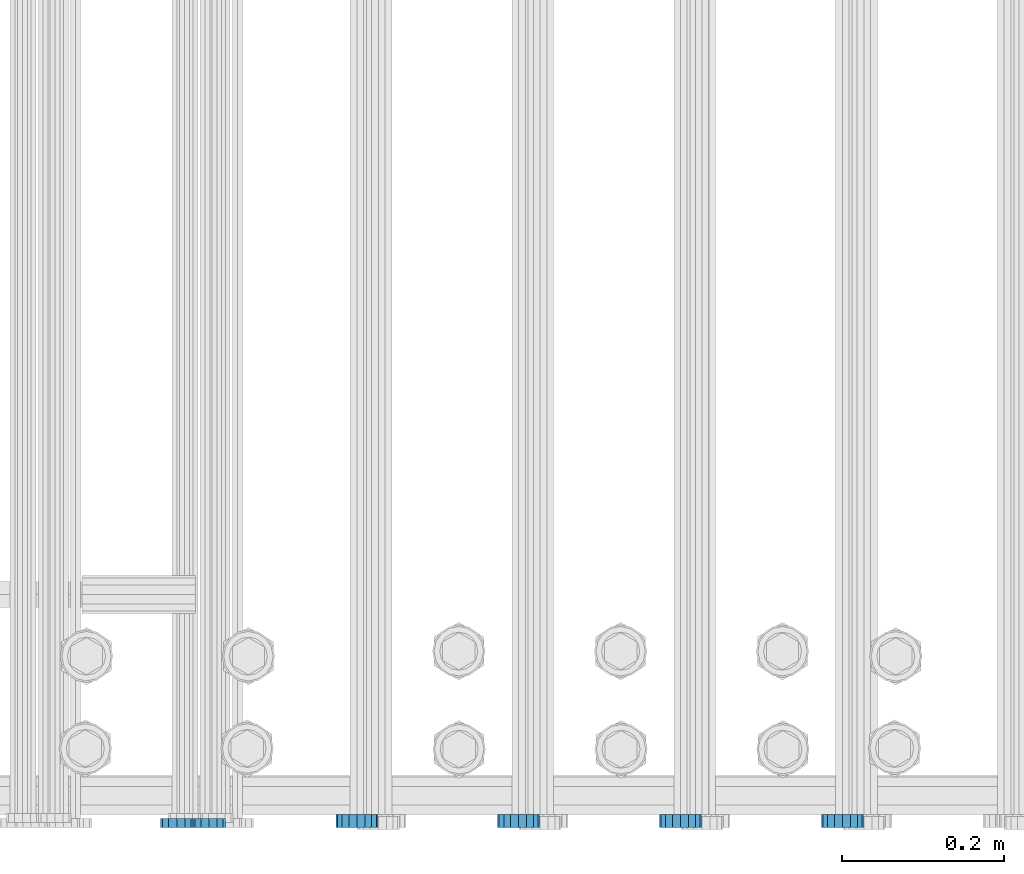
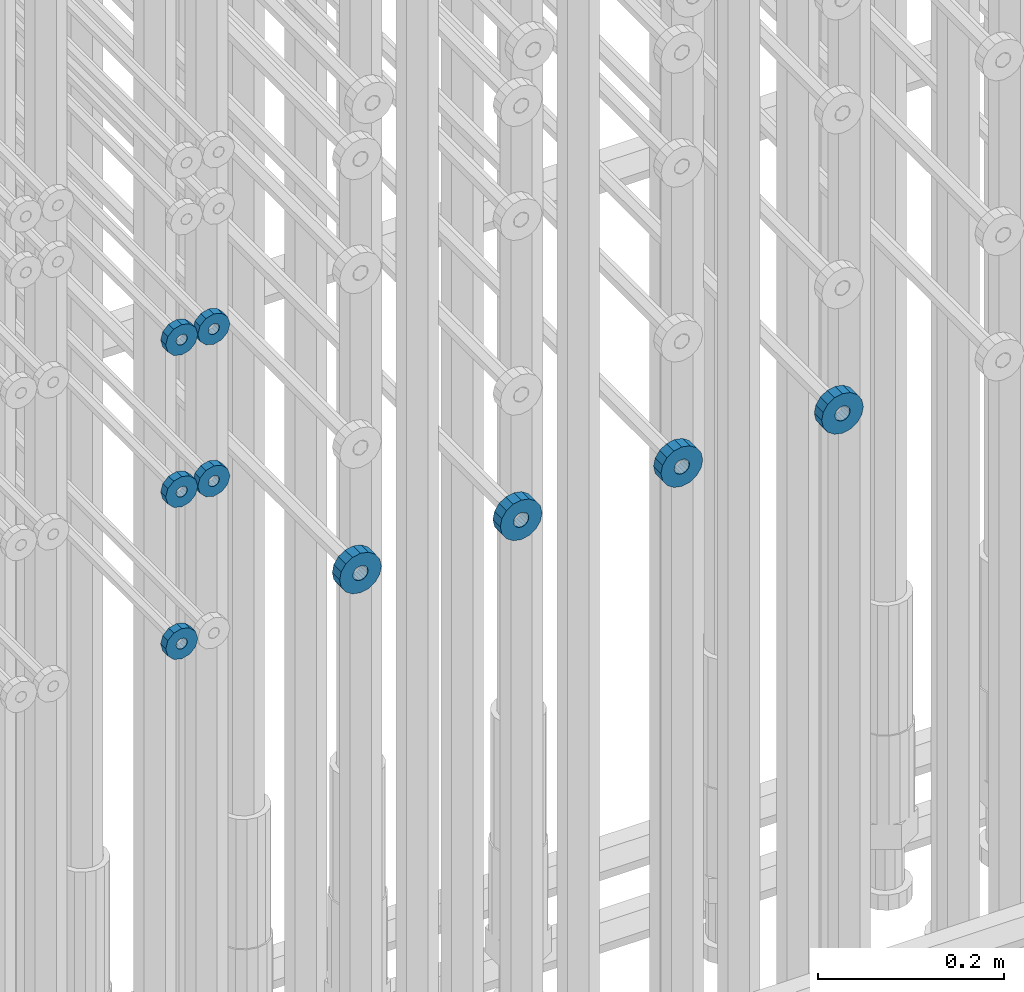
# One storey, part 134 of 177: 9 beams.
"""IFC2X3 building model written with IfcOpenShell, lengths in millimetres."""

import ifcopenshell
import ifcopenshell.guid

model = None  # the IFC model being written
_history = None  # IfcOwnerHistory: only IFC2X3 demands one
_inside = {}  # id of a spatial element -> (the spatial element, [elements in it])
_under = {}  # id of a project, library or spatial element -> (it, [spatial elements below it])
_declared = {}  # id of a project -> (the project, [libraries it declares])
_typed = {}  # id of a type object -> (the type object, [elements of that type])
_made_of = {}  # id of a material, layer set ... -> (it, [elements and type objects made of it])


def new_model(schema):
    """Start an empty IFC model of exactly this schema.

    Asked for "IFC4X3", IfcOpenShell would pick the latest addendum, in which some entities
    have other attributes; the version numbers below select the first issue.
    IFC2X3 requires an IfcOwnerHistory on every rooted entity: one is made here for all.
    """
    global model, _history
    if schema == "IFC4X3":
        model = ifcopenshell.file(schema_version=(4, 3, 0, 0))
    else:
        model = ifcopenshell.file(schema=schema)
    _inside.clear()
    _under.clear()
    _declared.clear()
    _typed.clear()
    _made_of.clear()
    _history = None
    if model.schema == "IFC2X3":
        org = make("IfcOrganization", Name="unknown")
        user = make(
            "IfcPersonAndOrganization",
            ThePerson=make("IfcPerson", FamilyName="unknown"),
            TheOrganization=org,
        )
        app = make(
            "IfcApplication",
            ApplicationDeveloper=org,
            Version="unknown",
            ApplicationFullName="unknown",
            ApplicationIdentifier="unknown",
        )
        _history = make(
            "IfcOwnerHistory",
            OwningUser=user,
            OwningApplication=app,
            ChangeAction="ADDED",
            CreationDate=0,
        )
    return model


def make(cls, **values):
    """One entity of the class cls with the attributes given. An attribute that is None is left unset."""
    return model.create_entity(
        cls, **{name: value for name, value in values.items() if value is not None}
    )


def rooted(cls, **values):
    """An entity with a GlobalId (a new one), such as an element, a storey or a relation."""
    return make(cls, GlobalId=ifcopenshell.guid.new(), OwnerHistory=_history, **values)


def si_unit(unit_type, name, prefix=None):
    """IfcSIUnit, for example si_unit("LENGTHUNIT", "METRE", prefix="MILLI")."""
    return make("IfcSIUnit", UnitType=unit_type, Prefix=prefix, Name=name)


def assignment(units):
    """IfcUnitAssignment: the units of a project."""
    return None if units is None else make("IfcUnitAssignment", Units=units)


def point(xyz):
    """IfcCartesianPoint."""
    return None if xyz is None else make("IfcCartesianPoint", Coordinates=xyz)


def direction(xyz):
    """IfcDirection."""
    return None if xyz is None else make("IfcDirection", DirectionRatios=xyz)


def frame(location, z_axis=None, x_axis=None):
    """IfcAxis2Placement3D, a coordinate frame: its origin and axes. An axis left out is left unset."""
    return make(
        "IfcAxis2Placement3D",
        Location=point(location),
        Axis=direction(z_axis),
        RefDirection=direction(x_axis),
    )


def origin_with_axes():
    """The frame at (0, 0, 0) with the z axis (0, 0, 1) and the x axis (1, 0, 0) written out."""
    return frame((0.0, 0.0, 0.0), z_axis=(0.0, 0.0, 1.0), x_axis=(1.0, 0.0, 0.0))


def place(relative_to, where):
    """IfcLocalPlacement: puts the frame where relative to a parent placement (None: the world)."""
    return make(
        "IfcLocalPlacement", PlacementRelTo=relative_to, RelativePlacement=where
    )


def context(
    kind, dimensions, precision=None, world=None, true_north=None, identifier=None
):
    """IfcGeometricRepresentationContext, for example the 3D "Model" context."""
    return make(
        "IfcGeometricRepresentationContext",
        ContextIdentifier=identifier,
        ContextType=kind,
        CoordinateSpaceDimension=dimensions,
        Precision=precision,
        WorldCoordinateSystem=world,
        TrueNorth=true_north,
    )


def subcontext(parent, identifier, kind, view, scale=None):
    """IfcGeometricRepresentationSubContext, for example "Body" below "Model"."""
    return make(
        "IfcGeometricRepresentationSubContext",
        ContextIdentifier=identifier,
        ContextType=kind,
        ParentContext=parent,
        TargetScale=scale,
        TargetView=view,
    )


def project(units=None, contexts=None):
    """IfcProject with its units and contexts."""
    return rooted(
        "IfcProject",
        Name="project",
        RepresentationContexts=contexts,
        UnitsInContext=assignment(units),
    )


def spatial(cls, under=None, at=None, **own):
    """A site, building, storey or space (cls), placed at a placement, below another one or the project."""
    s = rooted(cls, ObjectPlacement=at, **own)
    if under is not None:
        _under.setdefault(under.id(), (under, []))[1].append(s)
    return s


def faces_of(points, faces, orient=None, outer=None):
    """IfcFace entities. A face is a list of loops; a loop is a list of indices into points, from 0.

    orient and outer hold one flag for each loop. By default every Orientation is true, the
    first loop of a face is its IfcFaceOuterBound and the others are IfcFaceBound.
    """
    made = []
    for i, loops in enumerate(faces):
        bounds = []
        for j, loop in enumerate(loops):
            is_outer = j == 0 if outer is None else outer[i][j]
            bounds.append(
                make(
                    "IfcFaceOuterBound" if is_outer else "IfcFaceBound",
                    Bound=make("IfcPolyLoop", Polygon=[points[k] for k in loop]),
                    Orientation=True if orient is None else orient[i][j],
                )
            )
        made.append(make("IfcFace", Bounds=bounds))
    return made


def faceted_brep(points, faces, orient=None, outer=None, voids=None):
    """IfcFacetedBrep: a solid bounded by flat faces; with voids (closed shells), ...WithVoids."""
    shared = [point(p) for p in points]
    hull = make("IfcClosedShell", CfsFaces=faces_of(shared, faces, orient, outer))
    if voids is None:
        return make("IfcFacetedBrep", Outer=hull)
    return make(
        "IfcFacetedBrepWithVoids",
        Outer=hull,
        Voids=[
            make(cls, CfsFaces=faces_of(shared, fs, o, b)) for cls, fs, o, b in voids
        ],
    )


def shape(context_of_items, identifier, shape_type, items):
    """IfcShapeRepresentation: the items that make up one representation, for example the "Body"."""
    return make(
        "IfcShapeRepresentation",
        ContextOfItems=context_of_items,
        RepresentationIdentifier=identifier,
        RepresentationType=shape_type,
        Items=items,
    )


def material(Name=None, Category=None):
    """IfcMaterial."""
    return make("IfcMaterial", Name=Name, Category=Category)


def made_of(thing, what):
    """Note that an element or type object is made of a material, layer set ...; save() writes the relation."""
    if what is not None:
        _made_of.setdefault(what.id(), (what, []))[1].append(thing)
    return thing


def type_object(cls, material=None, **own):
    """A type object (cls), such as IfcWallType, which elements share."""
    return made_of(rooted(cls, **own), material)


def element(
    cls,
    number,
    at=None,
    inside=None,
    cuts=None,
    type_object=None,
    material=None,
    context=None,
    identifier="Body",
    shape_type=None,
    held_by="IfcProductDefinitionShape",
    body=None,
    shapes=None,
    **own,
):
    """One element of the class cls, such as IfcWall. Its Tag is "e" and its number.

    at: its placement. inside: the storey or other place that contains it. cuts: it is an
    opening in that element (IfcRelVoidsElement). A single representation is given by context,
    identifier, shape_type and body (its items); several are given by shapes. held_by: the class
    of the entity that holds the representations. save() writes the other relations.
    """
    e = rooted(cls, Tag="e%d" % number, ObjectPlacement=at, **own)
    if body is not None:
        shapes = [shape(context, identifier, shape_type, body)]
    if shapes is not None:
        e.Representation = make(held_by, Representations=shapes)
    if inside is not None:
        _inside.setdefault(inside.id(), (inside, []))[1].append(e)
    if cuts is not None:
        rooted(
            "IfcRelVoidsElement", RelatingBuildingElement=cuts, RelatedOpeningElement=e
        )
    if type_object is not None:
        _typed.setdefault(type_object.id(), (type_object, []))[1].append(e)
    return made_of(e, material)


def aggregate(whole, parts):
    """IfcRelAggregates: a whole, such as a stair, and the parts it consists of."""
    return rooted("IfcRelAggregates", RelatingObject=whole, RelatedObjects=parts)


def save(model, path):
    """Write the relations noted so far, then the file.

    IfcRelAggregates (storeys below a building ...), IfcRelContainedInSpatialStructure (elements
    in a storey), IfcRelDefinesByType, IfcRelAssociatesMaterial and IfcRelDeclares: one each for
    every whole, place, type object, material and project.
    """
    for whole, parts in _under.values():
        aggregate(whole, parts)
    for where, things in _inside.values():
        rooted(
            "IfcRelContainedInSpatialStructure",
            RelatedElements=things,
            RelatingStructure=where,
        )
    for kind, things in _typed.values():
        rooted("IfcRelDefinesByType", RelatedObjects=things, RelatingType=kind)
    for what, things in _made_of.values():
        rooted("IfcRelAssociatesMaterial", RelatedObjects=things, RelatingMaterial=what)
    for by, libraries in _declared.values():
        rooted("IfcRelDeclares", RelatingContext=by, RelatedDefinitions=libraries)
    model.write(path)


model = new_model("IFC2X3")

# Units and contexts
model_context_1 = context("Model", 3, precision=1e-05, world=origin_with_axes())
model_context_2 = context("Model", 3, precision=1e-05, world=origin_with_axes())
body_context = subcontext(model_context_2, "Body", "Model", "MODEL_VIEW")
ifc_project = project(units=[si_unit("LENGTHUNIT", "METRE", prefix="MILLI"), si_unit("AREAUNIT", "SQUARE_METRE"), si_unit("VOLUMEUNIT", "CUBIC_METRE"), si_unit("MASSUNIT", "GRAM", prefix="KILO"), si_unit("TIMEUNIT", "SECOND"), si_unit("PLANEANGLEUNIT", "RADIAN"), si_unit("SOLIDANGLEUNIT", "STERADIAN"), si_unit("THERMODYNAMICTEMPERATUREUNIT", "DEGREE_CELSIUS"), si_unit("LUMINOUSINTENSITYUNIT", "LUMEN")], contexts=[model_context_1])

# Site, building, storey
site_placement = place(None, origin_with_axes())
site = spatial("IfcSite", under=ifc_project, at=site_placement, CompositionType="ELEMENT")
building_placement = place(site_placement, origin_with_axes())
building = spatial("IfcBuilding", under=site, at=building_placement, Name="Undefined", CompositionType="ELEMENT")
storey_placement = place(building_placement, origin_with_axes())
storey = spatial("IfcBuildingStorey", under=building, at=storey_placement, Name="Undefined", CompositionType="ELEMENT", Elevation=0.0)

# Beams
ifc_material = material(Name="STEEL/Steel_Undefined")
beam_type_1 = type_object("IfcBeamType", PredefinedType="NOTDEFINED")
beam_1_placement = place(storey_placement, frame((2031926.99847313, 6205070.98588034, 20639.9868114202), z_axis=(0.0, 0.0, -1.0), x_axis=(0.0, -1.0, 0.0)))
element("IfcBeam", 1, at=beam_1_placement, inside=storey, type_object=beam_type_1, material=ifc_material, context=body_context, shape_type="Brep", body=[
    faceted_brep([(-3.63797880709171e-12, -7.0, -2.3283064365387e-10), (-8.62348444298797e-13, -6.06217782649107, 3.5), (10.9999999999964, -6.06217782665044, 3.49999999976717), (10.9999999999964, -7.0, -2.3283064365387e-10), (-3.63797880709171e-12, -3.5, 6.06217782618478), (11.0, -3.5, 6.06217782618478), (-1.72469688859759e-12, 0.0, 7.0), (11.0, 0.0, 6.99999999976717), (-3.63797880709171e-12, 3.5, 6.06217782618478), (11.0, 3.5, 6.06217782618478), (-8.62348444298795e-13, 6.06217782649107, 3.5), (10.9999999999964, 6.06217782665044, 3.49999999976717), (-3.63797880709171e-12, 7.0, -2.3283064365387e-10), (10.9999999999964, 7.0, -2.3283064365387e-10), (8.62348444298797e-13, 6.06217782649107, -3.5), (10.9999999999964, 6.06217782665044, -3.50000000023283), (-3.63797880709171e-12, 3.5, -6.06217782665044), (10.9999999999964, 3.5, -6.06217782665044), (1.72469688859759e-12, -2.72004641033163e-15, -7.0), (10.9999999999964, 0.0, -7.00000000023283), (-3.63797880709171e-12, -3.5, -6.06217782665044), (10.9999999999964, -3.5, -6.06217782665044), (8.62348444298796e-13, -6.06217782649107, -3.5), (10.9999999999964, -6.06217782665044, -3.50000000023283), (0.0, -20.0000000009313, 0.0), (0.0, -17.320508075878, -10.0), (10.9999999999964, -17.320508075878, -10.0000000002328), (10.9999999999964, -20.0, -2.3283064365387e-10), (0.0, -10.0000000009313, -17.3205080756452), (11.0, -10.0, -17.320508075878), (0.0, -1.86264514923096e-09, -19.9999999998836), (10.9999999999964, 0.0, -20.0000000002328), (0.0, 9.99999999906868, -17.3205080755288), (11.0, 10.0, -17.320508075878), (0.0, 17.320508075878, -10.0), (10.9999999999964, 17.320508075878, -10.0000000002328), (0.0, 19.9999999990687, 0.0), (10.9999999999964, 20.0, -2.3283064365387e-10), (0.0, 17.3205080740154, 10.0), (11.0, 17.320508075878, 9.99999999976717), (0.0, 9.99999999906868, 17.3205080757616), (10.9999999999964, 10.0, 17.3205080754124), (0.0, 0.0, 20.0000000001164), (10.9999999999964, 0.0, 19.9999999997672), (0.0, -10.0000000009313, 17.3205080757616), (10.9999999999964, -10.0, 17.3205080754124), (0.0, -17.3205080777407, 10.0000000001164), (11.0, -17.320508075878, 9.99999999976717)], [[[0, 1, 2, 3]], [[1, 4, 5, 2]], [[4, 6, 7, 5]], [[6, 8, 9, 7]], [[8, 10, 11, 9]], [[10, 12, 13, 11]], [[12, 14, 15, 13]], [[14, 16, 17, 15]], [[16, 18, 19, 17]], [[18, 20, 21, 19]], [[20, 22, 23, 21]], [[22, 0, 3, 23]], [[24, 25, 26, 27]], [[25, 28, 29, 26]], [[28, 30, 31, 29]], [[30, 32, 33, 31]], [[32, 34, 35, 33]], [[34, 36, 37, 35]], [[36, 38, 39, 37]], [[38, 40, 41, 39]], [[40, 42, 43, 41]], [[42, 44, 45, 43]], [[44, 46, 47, 45]], [[46, 24, 27, 47]], [[29, 31, 33, 35, 37, 39, 41, 43, 45, 47, 27, 26], [5, 7, 9, 11, 13, 15, 17, 19, 21, 23, 3, 2]], [[46, 44, 42, 40, 38, 36, 34, 32, 30, 28, 25, 24], [22, 20, 18, 16, 14, 12, 10, 8, 6, 4, 1, 0]]]),
])
beam_2_placement = place(storey_placement, frame((2031886.99847313, 6205070.98588034, 20639.9868114202), z_axis=(0.0, 0.0, -1.0), x_axis=(0.0, -1.0, 0.0)))
element("IfcBeam", 2, at=beam_2_placement, inside=storey, type_object=beam_type_1, material=ifc_material, context=body_context, shape_type="Brep", body=[
    faceted_brep([(-3.63797880709171e-12, -7.0, -2.3283064365387e-10), (-8.62348444298797e-13, -6.06217782649107, 3.5), (10.9999999999964, -6.06217782665044, 3.49999999976717), (10.9999999999964, -7.0, -2.3283064365387e-10), (-3.63797880709171e-12, -3.5, 6.06217782618478), (11.0, -3.5, 6.06217782618478), (-1.72469688859759e-12, 0.0, 7.0), (11.0, 0.0, 6.99999999976717), (-3.63797880709171e-12, 3.5, 6.06217782618478), (11.0, 3.5, 6.06217782618478), (-8.62348444298795e-13, 6.06217782649107, 3.5), (10.9999999999964, 6.06217782665044, 3.49999999976717), (-3.63797880709171e-12, 7.0, -2.3283064365387e-10), (10.9999999999964, 7.0, -2.3283064365387e-10), (8.62348444298797e-13, 6.06217782649107, -3.5), (10.9999999999964, 6.06217782665044, -3.50000000023283), (-3.63797880709171e-12, 3.5, -6.06217782665044), (10.9999999999964, 3.5, -6.06217782665044), (1.72469688859759e-12, -2.72004641033163e-15, -7.0), (10.9999999999964, 0.0, -7.00000000023283), (-3.63797880709171e-12, -3.5, -6.06217782665044), (10.9999999999964, -3.5, -6.06217782665044), (8.62348444298796e-13, -6.06217782649107, -3.5), (10.9999999999964, -6.06217782665044, -3.50000000023283), (0.0, -20.0000000009313, 0.0), (0.0, -17.320508075878, -10.0), (10.9999999999964, -17.320508075878, -10.0000000002328), (10.9999999999964, -20.0, -2.3283064365387e-10), (0.0, -10.0000000009313, -17.3205080756452), (11.0, -10.0, -17.320508075878), (0.0, -1.86264514923096e-09, -19.9999999998836), (10.9999999999964, 0.0, -20.0000000002328), (0.0, 9.99999999906868, -17.3205080755288), (11.0, 10.0, -17.320508075878), (0.0, 17.320508075878, -10.0), (10.9999999999964, 17.320508075878, -10.0000000002328), (0.0, 19.9999999990687, 0.0), (10.9999999999964, 20.0, -2.3283064365387e-10), (0.0, 17.3205080740154, 10.0), (11.0, 17.320508075878, 9.99999999976717), (0.0, 9.99999999906868, 17.3205080757616), (10.9999999999964, 10.0, 17.3205080754124), (0.0, 0.0, 20.0000000001164), (10.9999999999964, 0.0, 19.9999999997672), (0.0, -10.0000000009313, 17.3205080757616), (10.9999999999964, -10.0, 17.3205080754124), (0.0, -17.3205080777407, 10.0000000001164), (11.0, -17.320508075878, 9.99999999976717)], [[[0, 1, 2, 3]], [[1, 4, 5, 2]], [[4, 6, 7, 5]], [[6, 8, 9, 7]], [[8, 10, 11, 9]], [[10, 12, 13, 11]], [[12, 14, 15, 13]], [[14, 16, 17, 15]], [[16, 18, 19, 17]], [[18, 20, 21, 19]], [[20, 22, 23, 21]], [[22, 0, 3, 23]], [[24, 25, 26, 27]], [[25, 28, 29, 26]], [[28, 30, 31, 29]], [[30, 32, 33, 31]], [[32, 34, 35, 33]], [[34, 36, 37, 35]], [[36, 38, 39, 37]], [[38, 40, 41, 39]], [[40, 42, 43, 41]], [[42, 44, 45, 43]], [[44, 46, 47, 45]], [[46, 24, 27, 47]], [[29, 31, 33, 35, 37, 39, 41, 43, 45, 47, 27, 26], [5, 7, 9, 11, 13, 15, 17, 19, 21, 23, 3, 2]], [[46, 44, 42, 40, 38, 36, 34, 32, 30, 28, 25, 24], [22, 20, 18, 16, 14, 12, 10, 8, 6, 4, 1, 0]]]),
])
beam_3_placement = place(storey_placement, frame((2031926.99847313, 6205070.98588034, 20439.9868114202), z_axis=(0.0, 0.0, -1.0), x_axis=(0.0, -1.0, 0.0)))
element("IfcBeam", 3, at=beam_3_placement, inside=storey, type_object=beam_type_1, material=ifc_material, context=body_context, shape_type="Brep", body=[
    faceted_brep([(-3.63797880709171e-12, -7.0, -2.3283064365387e-10), (-8.62348444298797e-13, -6.06217782649107, 3.5), (10.9999999999964, -6.06217782665044, 3.49999999976717), (10.9999999999964, -7.0, -2.3283064365387e-10), (-3.63797880709171e-12, -3.5, 6.06217782618478), (11.0, -3.5, 6.06217782618478), (-1.72469688859759e-12, 0.0, 7.0), (11.0, 0.0, 6.99999999976717), (-3.63797880709171e-12, 3.5, 6.06217782618478), (11.0, 3.5, 6.06217782618478), (-8.62348444298795e-13, 6.06217782649107, 3.5), (10.9999999999964, 6.06217782665044, 3.49999999976717), (-3.63797880709171e-12, 7.0, -2.3283064365387e-10), (10.9999999999964, 7.0, -2.3283064365387e-10), (8.62348444298797e-13, 6.06217782649107, -3.5), (10.9999999999964, 6.06217782665044, -3.50000000023283), (-3.63797880709171e-12, 3.5, -6.06217782665044), (10.9999999999964, 3.5, -6.06217782665044), (1.72469688859759e-12, -2.72004641033163e-15, -7.0), (10.9999999999964, 0.0, -7.00000000023283), (-3.63797880709171e-12, -3.5, -6.06217782665044), (10.9999999999964, -3.5, -6.06217782665044), (8.62348444298796e-13, -6.06217782649107, -3.5), (10.9999999999964, -6.06217782665044, -3.50000000023283), (0.0, -20.0000000009313, 0.0), (0.0, -17.320508075878, -10.0), (10.9999999999964, -17.320508075878, -10.0000000002328), (10.9999999999964, -20.0, -2.3283064365387e-10), (0.0, -10.0000000009313, -17.3205080756452), (11.0, -10.0, -17.320508075878), (0.0, -1.86264514923096e-09, -19.9999999998836), (10.9999999999964, 0.0, -20.0000000002328), (0.0, 9.99999999906868, -17.3205080755288), (11.0, 10.0, -17.320508075878), (0.0, 17.320508075878, -10.0), (10.9999999999964, 17.320508075878, -10.0000000002328), (0.0, 19.9999999990687, 0.0), (10.9999999999964, 20.0, -2.3283064365387e-10), (0.0, 17.3205080740154, 10.0), (11.0, 17.320508075878, 9.99999999976717), (0.0, 9.99999999906868, 17.3205080757616), (10.9999999999964, 10.0, 17.3205080754124), (0.0, 0.0, 20.0000000001164), (10.9999999999964, 0.0, 19.9999999997672), (0.0, -10.0000000009313, 17.3205080757616), (10.9999999999964, -10.0, 17.3205080754124), (0.0, -17.3205080777407, 10.0000000001164), (11.0, -17.320508075878, 9.99999999976717)], [[[0, 1, 2, 3]], [[1, 4, 5, 2]], [[4, 6, 7, 5]], [[6, 8, 9, 7]], [[8, 10, 11, 9]], [[10, 12, 13, 11]], [[12, 14, 15, 13]], [[14, 16, 17, 15]], [[16, 18, 19, 17]], [[18, 20, 21, 19]], [[20, 22, 23, 21]], [[22, 0, 3, 23]], [[24, 25, 26, 27]], [[25, 28, 29, 26]], [[28, 30, 31, 29]], [[30, 32, 33, 31]], [[32, 34, 35, 33]], [[34, 36, 37, 35]], [[36, 38, 39, 37]], [[38, 40, 41, 39]], [[40, 42, 43, 41]], [[42, 44, 45, 43]], [[44, 46, 47, 45]], [[46, 24, 27, 47]], [[29, 31, 33, 35, 37, 39, 41, 43, 45, 47, 27, 26], [5, 7, 9, 11, 13, 15, 17, 19, 21, 23, 3, 2]], [[46, 44, 42, 40, 38, 36, 34, 32, 30, 28, 25, 24], [22, 20, 18, 16, 14, 12, 10, 8, 6, 4, 1, 0]]]),
])
beam_4_placement = place(storey_placement, frame((2031886.99847313, 6205070.98588034, 20439.9868114202), z_axis=(0.0, 0.0, -1.0), x_axis=(0.0, -1.0, 0.0)))
element("IfcBeam", 4, at=beam_4_placement, inside=storey, type_object=beam_type_1, material=ifc_material, context=body_context, shape_type="Brep", body=[
    faceted_brep([(-3.63797880709171e-12, -7.0, -2.3283064365387e-10), (-8.62348444298797e-13, -6.06217782649107, 3.5), (10.9999999999964, -6.06217782665044, 3.49999999976717), (10.9999999999964, -7.0, -2.3283064365387e-10), (-3.63797880709171e-12, -3.5, 6.06217782618478), (11.0, -3.5, 6.06217782618478), (-1.72469688859759e-12, 0.0, 7.0), (11.0, 0.0, 6.99999999976717), (-3.63797880709171e-12, 3.5, 6.06217782618478), (11.0, 3.5, 6.06217782618478), (-8.62348444298795e-13, 6.06217782649107, 3.5), (10.9999999999964, 6.06217782665044, 3.49999999976717), (-3.63797880709171e-12, 7.0, -2.3283064365387e-10), (10.9999999999964, 7.0, -2.3283064365387e-10), (8.62348444298797e-13, 6.06217782649107, -3.5), (10.9999999999964, 6.06217782665044, -3.50000000023283), (-3.63797880709171e-12, 3.5, -6.06217782665044), (10.9999999999964, 3.5, -6.06217782665044), (1.72469688859759e-12, -2.72004641033163e-15, -7.0), (10.9999999999964, 0.0, -7.00000000023283), (-3.63797880709171e-12, -3.5, -6.06217782665044), (10.9999999999964, -3.5, -6.06217782665044), (8.62348444298796e-13, -6.06217782649107, -3.5), (10.9999999999964, -6.06217782665044, -3.50000000023283), (0.0, -20.0000000009313, 0.0), (0.0, -17.320508075878, -10.0), (10.9999999999964, -17.320508075878, -10.0000000002328), (10.9999999999964, -20.0, -2.3283064365387e-10), (0.0, -10.0000000009313, -17.3205080756452), (11.0, -10.0, -17.320508075878), (0.0, -1.86264514923096e-09, -19.9999999998836), (10.9999999999964, 0.0, -20.0000000002328), (0.0, 9.99999999906868, -17.3205080755288), (11.0, 10.0, -17.320508075878), (0.0, 17.320508075878, -10.0), (10.9999999999964, 17.320508075878, -10.0000000002328), (0.0, 19.9999999990687, 0.0), (10.9999999999964, 20.0, -2.3283064365387e-10), (0.0, 17.3205080740154, 10.0), (11.0, 17.320508075878, 9.99999999976717), (0.0, 9.99999999906868, 17.3205080757616), (10.9999999999964, 10.0, 17.3205080754124), (0.0, 0.0, 20.0000000001164), (10.9999999999964, 0.0, 19.9999999997672), (0.0, -10.0000000009313, 17.3205080757616), (10.9999999999964, -10.0, 17.3205080754124), (0.0, -17.3205080777407, 10.0000000001164), (11.0, -17.320508075878, 9.99999999976717)], [[[0, 1, 2, 3]], [[1, 4, 5, 2]], [[4, 6, 7, 5]], [[6, 8, 9, 7]], [[8, 10, 11, 9]], [[10, 12, 13, 11]], [[12, 14, 15, 13]], [[14, 16, 17, 15]], [[16, 18, 19, 17]], [[18, 20, 21, 19]], [[20, 22, 23, 21]], [[22, 0, 3, 23]], [[24, 25, 26, 27]], [[25, 28, 29, 26]], [[28, 30, 31, 29]], [[30, 32, 33, 31]], [[32, 34, 35, 33]], [[34, 36, 37, 35]], [[36, 38, 39, 37]], [[38, 40, 41, 39]], [[40, 42, 43, 41]], [[42, 44, 45, 43]], [[44, 46, 47, 45]], [[46, 24, 27, 47]], [[29, 31, 33, 35, 37, 39, 41, 43, 45, 47, 27, 26], [5, 7, 9, 11, 13, 15, 17, 19, 21, 23, 3, 2]], [[46, 44, 42, 40, 38, 36, 34, 32, 30, 28, 25, 24], [22, 20, 18, 16, 14, 12, 10, 8, 6, 4, 1, 0]]]),
])
beam_5_placement = place(storey_placement, frame((2031886.99847313, 6205070.98588034, 20239.9868114202), z_axis=(0.0, 0.0, -1.0), x_axis=(0.0, -1.0, 0.0)))
element("IfcBeam", 5, at=beam_5_placement, inside=storey, type_object=beam_type_1, material=ifc_material, context=body_context, shape_type="Brep", body=[
    faceted_brep([(-3.63797880709171e-12, -7.0, -2.3283064365387e-10), (-8.62348444298797e-13, -6.06217782649107, 3.5), (10.9999999999964, -6.06217782665044, 3.49999999976717), (10.9999999999964, -7.0, -2.3283064365387e-10), (-3.63797880709171e-12, -3.5, 6.06217782618478), (11.0, -3.5, 6.06217782618478), (-1.72469688859759e-12, 0.0, 7.0), (11.0, 0.0, 6.99999999976717), (-3.63797880709171e-12, 3.5, 6.06217782618478), (11.0, 3.5, 6.06217782618478), (-8.62348444298795e-13, 6.06217782649107, 3.5), (10.9999999999964, 6.06217782665044, 3.49999999976717), (-3.63797880709171e-12, 7.0, -2.3283064365387e-10), (10.9999999999964, 7.0, -2.3283064365387e-10), (8.62348444298797e-13, 6.06217782649107, -3.5), (10.9999999999964, 6.06217782665044, -3.50000000023283), (-3.63797880709171e-12, 3.5, -6.06217782665044), (10.9999999999964, 3.5, -6.06217782665044), (1.72469688859759e-12, -2.72004641033163e-15, -7.0), (10.9999999999964, 0.0, -7.00000000023283), (-3.63797880709171e-12, -3.5, -6.06217782665044), (10.9999999999964, -3.5, -6.06217782665044), (8.62348444298796e-13, -6.06217782649107, -3.5), (10.9999999999964, -6.06217782665044, -3.50000000023283), (0.0, -20.0000000009313, 0.0), (0.0, -17.320508075878, -10.0), (10.9999999999964, -17.320508075878, -10.0000000002328), (10.9999999999964, -20.0, -2.3283064365387e-10), (0.0, -10.0000000009313, -17.3205080756452), (11.0, -10.0, -17.320508075878), (0.0, -1.86264514923096e-09, -19.9999999998836), (10.9999999999964, 0.0, -20.0000000002328), (0.0, 9.99999999906868, -17.3205080755288), (11.0, 10.0, -17.320508075878), (0.0, 17.320508075878, -10.0), (10.9999999999964, 17.320508075878, -10.0000000002328), (0.0, 19.9999999990687, 0.0), (10.9999999999964, 20.0, -2.3283064365387e-10), (0.0, 17.3205080740154, 10.0), (11.0, 17.320508075878, 9.99999999976717), (0.0, 9.99999999906868, 17.3205080757616), (10.9999999999964, 10.0, 17.3205080754124), (0.0, 0.0, 20.0000000001164), (10.9999999999964, 0.0, 19.9999999997672), (0.0, -10.0000000009313, 17.3205080757616), (10.9999999999964, -10.0, 17.3205080754124), (0.0, -17.3205080777407, 10.0000000001164), (11.0, -17.320508075878, 9.99999999976717)], [[[0, 1, 2, 3]], [[1, 4, 5, 2]], [[4, 6, 7, 5]], [[6, 8, 9, 7]], [[8, 10, 11, 9]], [[10, 12, 13, 11]], [[12, 14, 15, 13]], [[14, 16, 17, 15]], [[16, 18, 19, 17]], [[18, 20, 21, 19]], [[20, 22, 23, 21]], [[22, 0, 3, 23]], [[24, 25, 26, 27]], [[25, 28, 29, 26]], [[28, 30, 31, 29]], [[30, 32, 33, 31]], [[32, 34, 35, 33]], [[34, 36, 37, 35]], [[36, 38, 39, 37]], [[38, 40, 41, 39]], [[40, 42, 43, 41]], [[42, 44, 45, 43]], [[44, 46, 47, 45]], [[46, 24, 27, 47]], [[29, 31, 33, 35, 37, 39, 41, 43, 45, 47, 27, 26], [5, 7, 9, 11, 13, 15, 17, 19, 21, 23, 3, 2]], [[46, 44, 42, 40, 38, 36, 34, 32, 30, 28, 25, 24], [22, 20, 18, 16, 14, 12, 10, 8, 6, 4, 1, 0]]]),
])
beam_type_2 = type_object("IfcBeamType", PredefinedType="NOTDEFINED")
beam_6_placement = place(storey_placement, frame((2032709.49847313, 6205075.98588034, 20254.9868114202), z_axis=(0.0, 0.0, -1.0), x_axis=(0.0, -1.0, 0.0)))
element("IfcBeam", 6, at=beam_6_placement, inside=storey, type_object=beam_type_2, material=ifc_material, context=body_context, shape_type="Brep", body=[
    faceted_brep([(0.0, -9.5, 0.0), (0.0, -8.77685555908829, 3.63549260746731), (16.0, -8.77685555908829, 3.63549260746731), (16.0, -9.5, 0.0), (0.0, -6.71751442085952, 6.71751442127061), (16.0, -6.71751442085952, 6.71751442127061), (0.0, -3.63549260701984, 8.77685555885546), (16.0, -3.63549260701984, 8.77685555885546), (-2.02452244836415e-12, 0.0, 9.5), (16.0, 0.0, 9.5), (0.0, 3.63549260701984, 8.77685555885546), (16.0, 3.63549260701984, 8.77685555885546), (0.0, 6.71751442085952, 6.71751442127061), (16.0, 6.71751442085952, 6.71751442127061), (0.0, 8.77685555908829, 3.63549260746731), (16.0, 8.77685555908829, 3.63549260746731), (0.0, 9.5, 0.0), (16.0, 9.5, 0.0), (0.0, 8.77685555908829, -3.63549260746731), (16.0, 8.77685555908829, -3.63549260746731), (0.0, 6.71751442085952, -6.71751442127061), (16.0, 6.71751442085952, -6.71751442127061), (0.0, 3.63549260701984, -8.77685555885546), (16.0, 3.63549260701984, -8.77685555885546), (2.02452244836415e-12, -3.69149155687865e-15, -9.5), (16.0, 0.0, -9.5), (0.0, -3.63549260701984, -8.77685555885546), (16.0, -3.63549260701984, -8.77685555885546), (0.0, -6.71751442085952, -6.71751442127061), (16.0, -6.71751442085952, -6.71751442127061), (0.0, -8.77685555908829, -3.63549260746731), (16.0, -8.77685555908829, -3.63549260746731), (0.0, -26.0, 0.0), (0.0, -24.0208678450435, -9.94976924149159), (16.0, -24.0208678450435, -9.94976924149159), (16.0, -26.0, 0.0), (0.0, -18.3847763109952, -18.3847763108497), (16.0, -18.3847763109952, -18.3847763108497), (0.0, -9.94976924173534, -24.0208678452946), (16.0, -9.94976924173534, -24.0208678452946), (0.0, 0.0, -26.0), (16.0, 0.0, -26.0), (0.0, 9.94976924173534, -24.0208678452946), (16.0, 9.94976924173534, -24.0208678452946), (0.0, 18.3847763109952, -18.3847763108497), (16.0, 18.3847763109952, -18.3847763108497), (0.0, 24.0208678450435, -9.94976924149159), (16.0, 24.0208678450435, -9.94976924149159), (0.0, 26.0, 0.0), (16.0, 26.0, 0.0), (0.0, 24.0208678450435, 9.94976924149159), (16.0, 24.0208678450435, 9.94976924149159), (0.0, 18.3847763109952, 18.3847763108497), (16.0, 18.3847763109952, 18.3847763108497), (0.0, 9.94976924173534, 24.0208678452946), (16.0, 9.94976924173534, 24.0208678452946), (0.0, 0.0, 26.0), (16.0, 0.0, 26.0), (0.0, -9.94976924173534, 24.0208678452946), (16.0, -9.94976924173534, 24.0208678452946), (0.0, -18.3847763109952, 18.3847763108497), (16.0, -18.3847763109952, 18.3847763108497), (0.0, -24.0208678450435, 9.94976924149159), (16.0, -24.0208678450435, 9.94976924149159)], [[[0, 1, 2, 3]], [[1, 4, 5, 2]], [[4, 6, 7, 5]], [[6, 8, 9, 7]], [[8, 10, 11, 9]], [[10, 12, 13, 11]], [[12, 14, 15, 13]], [[14, 16, 17, 15]], [[16, 18, 19, 17]], [[18, 20, 21, 19]], [[20, 22, 23, 21]], [[22, 24, 25, 23]], [[24, 26, 27, 25]], [[26, 28, 29, 27]], [[28, 30, 31, 29]], [[30, 0, 3, 31]], [[32, 33, 34, 35]], [[33, 36, 37, 34]], [[36, 38, 39, 37]], [[38, 40, 41, 39]], [[40, 42, 43, 41]], [[42, 44, 45, 43]], [[44, 46, 47, 45]], [[46, 48, 49, 47]], [[48, 50, 51, 49]], [[50, 52, 53, 51]], [[52, 54, 55, 53]], [[54, 56, 57, 55]], [[56, 58, 59, 57]], [[58, 60, 61, 59]], [[60, 62, 63, 61]], [[62, 32, 35, 63]], [[37, 39, 41, 43, 45, 47, 49, 51, 53, 55, 57, 59, 61, 63, 35, 34], [5, 7, 9, 11, 13, 15, 17, 19, 21, 23, 25, 27, 29, 31, 3, 2]], [[62, 60, 58, 56, 54, 52, 50, 48, 46, 44, 42, 40, 38, 36, 33, 32], [30, 28, 26, 24, 22, 20, 18, 16, 14, 12, 10, 8, 6, 4, 1, 0]]]),
])
beam_7_placement = place(storey_placement, frame((2032509.49847313, 6205075.98588034, 20254.9868114202), z_axis=(0.0, 0.0, -1.0), x_axis=(0.0, -1.0, 0.0)))
element("IfcBeam", 7, at=beam_7_placement, inside=storey, type_object=beam_type_2, material=ifc_material, context=body_context, shape_type="Brep", body=[
    faceted_brep([(0.0, -9.5, 0.0), (0.0, -8.77685555908829, 3.63549260746731), (16.0, -8.77685555908829, 3.63549260746731), (16.0, -9.5, 0.0), (0.0, -6.71751442085952, 6.71751442127061), (16.0, -6.71751442085952, 6.71751442127061), (0.0, -3.63549260701984, 8.77685555885546), (16.0, -3.63549260701984, 8.77685555885546), (-2.02452244836415e-12, 0.0, 9.5), (16.0, 0.0, 9.5), (0.0, 3.63549260701984, 8.77685555885546), (16.0, 3.63549260701984, 8.77685555885546), (0.0, 6.71751442085952, 6.71751442127061), (16.0, 6.71751442085952, 6.71751442127061), (0.0, 8.77685555908829, 3.63549260746731), (16.0, 8.77685555908829, 3.63549260746731), (0.0, 9.5, 0.0), (16.0, 9.5, 0.0), (0.0, 8.77685555908829, -3.63549260746731), (16.0, 8.77685555908829, -3.63549260746731), (0.0, 6.71751442085952, -6.71751442127061), (16.0, 6.71751442085952, -6.71751442127061), (0.0, 3.63549260701984, -8.77685555885546), (16.0, 3.63549260701984, -8.77685555885546), (2.02452244836415e-12, -3.69149155687865e-15, -9.5), (16.0, 0.0, -9.5), (0.0, -3.63549260701984, -8.77685555885546), (16.0, -3.63549260701984, -8.77685555885546), (0.0, -6.71751442085952, -6.71751442127061), (16.0, -6.71751442085952, -6.71751442127061), (0.0, -8.77685555908829, -3.63549260746731), (16.0, -8.77685555908829, -3.63549260746731), (0.0, -26.0, 0.0), (0.0, -24.0208678450435, -9.94976924149159), (16.0, -24.0208678450435, -9.94976924149159), (16.0, -26.0, 0.0), (0.0, -18.3847763109952, -18.3847763108497), (16.0, -18.3847763109952, -18.3847763108497), (0.0, -9.94976924173534, -24.0208678452946), (16.0, -9.94976924173534, -24.0208678452946), (0.0, 0.0, -26.0), (16.0, 0.0, -26.0), (0.0, 9.94976924173534, -24.0208678452946), (16.0, 9.94976924173534, -24.0208678452946), (0.0, 18.3847763109952, -18.3847763108497), (16.0, 18.3847763109952, -18.3847763108497), (0.0, 24.0208678450435, -9.94976924149159), (16.0, 24.0208678450435, -9.94976924149159), (0.0, 26.0, 0.0), (16.0, 26.0, 0.0), (0.0, 24.0208678450435, 9.94976924149159), (16.0, 24.0208678450435, 9.94976924149159), (0.0, 18.3847763109952, 18.3847763108497), (16.0, 18.3847763109952, 18.3847763108497), (0.0, 9.94976924173534, 24.0208678452946), (16.0, 9.94976924173534, 24.0208678452946), (0.0, 0.0, 26.0), (16.0, 0.0, 26.0), (0.0, -9.94976924173534, 24.0208678452946), (16.0, -9.94976924173534, 24.0208678452946), (0.0, -18.3847763109952, 18.3847763108497), (16.0, -18.3847763109952, 18.3847763108497), (0.0, -24.0208678450435, 9.94976924149159), (16.0, -24.0208678450435, 9.94976924149159)], [[[0, 1, 2, 3]], [[1, 4, 5, 2]], [[4, 6, 7, 5]], [[6, 8, 9, 7]], [[8, 10, 11, 9]], [[10, 12, 13, 11]], [[12, 14, 15, 13]], [[14, 16, 17, 15]], [[16, 18, 19, 17]], [[18, 20, 21, 19]], [[20, 22, 23, 21]], [[22, 24, 25, 23]], [[24, 26, 27, 25]], [[26, 28, 29, 27]], [[28, 30, 31, 29]], [[30, 0, 3, 31]], [[32, 33, 34, 35]], [[33, 36, 37, 34]], [[36, 38, 39, 37]], [[38, 40, 41, 39]], [[40, 42, 43, 41]], [[42, 44, 45, 43]], [[44, 46, 47, 45]], [[46, 48, 49, 47]], [[48, 50, 51, 49]], [[50, 52, 53, 51]], [[52, 54, 55, 53]], [[54, 56, 57, 55]], [[56, 58, 59, 57]], [[58, 60, 61, 59]], [[60, 62, 63, 61]], [[62, 32, 35, 63]], [[37, 39, 41, 43, 45, 47, 49, 51, 53, 55, 57, 59, 61, 63, 35, 34], [5, 7, 9, 11, 13, 15, 17, 19, 21, 23, 25, 27, 29, 31, 3, 2]], [[62, 60, 58, 56, 54, 52, 50, 48, 46, 44, 42, 40, 38, 36, 33, 32], [30, 28, 26, 24, 22, 20, 18, 16, 14, 12, 10, 8, 6, 4, 1, 0]]]),
])
beam_8_placement = place(storey_placement, frame((2032309.49847313, 6205075.98588034, 20254.9868114202), z_axis=(0.0, 0.0, -1.0), x_axis=(0.0, -1.0, 0.0)))
element("IfcBeam", 8, at=beam_8_placement, inside=storey, type_object=beam_type_2, material=ifc_material, context=body_context, shape_type="Brep", body=[
    faceted_brep([(0.0, -9.5, 0.0), (0.0, -8.77685555908829, 3.63549260746731), (16.0, -8.77685555908829, 3.63549260746731), (16.0, -9.5, 0.0), (0.0, -6.71751442085952, 6.71751442127061), (16.0, -6.71751442085952, 6.71751442127061), (0.0, -3.63549260701984, 8.77685555885546), (16.0, -3.63549260701984, 8.77685555885546), (-2.02452244836415e-12, 0.0, 9.5), (16.0, 0.0, 9.5), (0.0, 3.63549260701984, 8.77685555885546), (16.0, 3.63549260701984, 8.77685555885546), (0.0, 6.71751442085952, 6.71751442127061), (16.0, 6.71751442085952, 6.71751442127061), (0.0, 8.77685555908829, 3.63549260746731), (16.0, 8.77685555908829, 3.63549260746731), (0.0, 9.5, 0.0), (16.0, 9.5, 0.0), (0.0, 8.77685555908829, -3.63549260746731), (16.0, 8.77685555908829, -3.63549260746731), (0.0, 6.71751442085952, -6.71751442127061), (16.0, 6.71751442085952, -6.71751442127061), (0.0, 3.63549260701984, -8.77685555885546), (16.0, 3.63549260701984, -8.77685555885546), (2.02452244836415e-12, -3.69149155687865e-15, -9.5), (16.0, 0.0, -9.5), (0.0, -3.63549260701984, -8.77685555885546), (16.0, -3.63549260701984, -8.77685555885546), (0.0, -6.71751442085952, -6.71751442127061), (16.0, -6.71751442085952, -6.71751442127061), (0.0, -8.77685555908829, -3.63549260746731), (16.0, -8.77685555908829, -3.63549260746731), (0.0, -26.0, 0.0), (0.0, -24.0208678450435, -9.94976924149159), (16.0, -24.0208678450435, -9.94976924149159), (16.0, -26.0, 0.0), (0.0, -18.3847763109952, -18.3847763108497), (16.0, -18.3847763109952, -18.3847763108497), (0.0, -9.94976924173534, -24.0208678452946), (16.0, -9.94976924173534, -24.0208678452946), (0.0, 0.0, -26.0), (16.0, 0.0, -26.0), (0.0, 9.94976924173534, -24.0208678452946), (16.0, 9.94976924173534, -24.0208678452946), (0.0, 18.3847763109952, -18.3847763108497), (16.0, 18.3847763109952, -18.3847763108497), (0.0, 24.0208678450435, -9.94976924149159), (16.0, 24.0208678450435, -9.94976924149159), (0.0, 26.0, 0.0), (16.0, 26.0, 0.0), (0.0, 24.0208678450435, 9.94976924149159), (16.0, 24.0208678450435, 9.94976924149159), (0.0, 18.3847763109952, 18.3847763108497), (16.0, 18.3847763109952, 18.3847763108497), (0.0, 9.94976924173534, 24.0208678452946), (16.0, 9.94976924173534, 24.0208678452946), (0.0, 0.0, 26.0), (16.0, 0.0, 26.0), (0.0, -9.94976924173534, 24.0208678452946), (16.0, -9.94976924173534, 24.0208678452946), (0.0, -18.3847763109952, 18.3847763108497), (16.0, -18.3847763109952, 18.3847763108497), (0.0, -24.0208678450435, 9.94976924149159), (16.0, -24.0208678450435, 9.94976924149159)], [[[0, 1, 2, 3]], [[1, 4, 5, 2]], [[4, 6, 7, 5]], [[6, 8, 9, 7]], [[8, 10, 11, 9]], [[10, 12, 13, 11]], [[12, 14, 15, 13]], [[14, 16, 17, 15]], [[16, 18, 19, 17]], [[18, 20, 21, 19]], [[20, 22, 23, 21]], [[22, 24, 25, 23]], [[24, 26, 27, 25]], [[26, 28, 29, 27]], [[28, 30, 31, 29]], [[30, 0, 3, 31]], [[32, 33, 34, 35]], [[33, 36, 37, 34]], [[36, 38, 39, 37]], [[38, 40, 41, 39]], [[40, 42, 43, 41]], [[42, 44, 45, 43]], [[44, 46, 47, 45]], [[46, 48, 49, 47]], [[48, 50, 51, 49]], [[50, 52, 53, 51]], [[52, 54, 55, 53]], [[54, 56, 57, 55]], [[56, 58, 59, 57]], [[58, 60, 61, 59]], [[60, 62, 63, 61]], [[62, 32, 35, 63]], [[37, 39, 41, 43, 45, 47, 49, 51, 53, 55, 57, 59, 61, 63, 35, 34], [5, 7, 9, 11, 13, 15, 17, 19, 21, 23, 25, 27, 29, 31, 3, 2]], [[62, 60, 58, 56, 54, 52, 50, 48, 46, 44, 42, 40, 38, 36, 33, 32], [30, 28, 26, 24, 22, 20, 18, 16, 14, 12, 10, 8, 6, 4, 1, 0]]]),
])
beam_9_placement = place(storey_placement, frame((2032109.49847313, 6205075.98588034, 20254.9868114202), z_axis=(0.0, 0.0, -1.0), x_axis=(0.0, -1.0, 0.0)))
element("IfcBeam", 9, at=beam_9_placement, inside=storey, type_object=beam_type_2, material=ifc_material, context=body_context, shape_type="Brep", body=[
    faceted_brep([(0.0, -9.5, 0.0), (0.0, -8.77685555908829, 3.63549260746731), (16.0, -8.77685555908829, 3.63549260746731), (16.0, -9.5, 0.0), (0.0, -6.71751442085952, 6.71751442127061), (16.0, -6.71751442085952, 6.71751442127061), (0.0, -3.63549260701984, 8.77685555885546), (16.0, -3.63549260701984, 8.77685555885546), (-2.02452244836415e-12, 0.0, 9.5), (16.0, 0.0, 9.5), (0.0, 3.63549260701984, 8.77685555885546), (16.0, 3.63549260701984, 8.77685555885546), (0.0, 6.71751442085952, 6.71751442127061), (16.0, 6.71751442085952, 6.71751442127061), (0.0, 8.77685555908829, 3.63549260746731), (16.0, 8.77685555908829, 3.63549260746731), (0.0, 9.5, 0.0), (16.0, 9.5, 0.0), (0.0, 8.77685555908829, -3.63549260746731), (16.0, 8.77685555908829, -3.63549260746731), (0.0, 6.71751442085952, -6.71751442127061), (16.0, 6.71751442085952, -6.71751442127061), (0.0, 3.63549260701984, -8.77685555885546), (16.0, 3.63549260701984, -8.77685555885546), (2.02452244836415e-12, -3.69149155687865e-15, -9.5), (16.0, 0.0, -9.5), (0.0, -3.63549260701984, -8.77685555885546), (16.0, -3.63549260701984, -8.77685555885546), (0.0, -6.71751442085952, -6.71751442127061), (16.0, -6.71751442085952, -6.71751442127061), (0.0, -8.77685555908829, -3.63549260746731), (16.0, -8.77685555908829, -3.63549260746731), (0.0, -26.0, 0.0), (0.0, -24.0208678450435, -9.94976924149159), (16.0, -24.0208678450435, -9.94976924149159), (16.0, -26.0, 0.0), (0.0, -18.3847763109952, -18.3847763108497), (16.0, -18.3847763109952, -18.3847763108497), (0.0, -9.94976924173534, -24.0208678452946), (16.0, -9.94976924173534, -24.0208678452946), (0.0, 0.0, -26.0), (16.0, 0.0, -26.0), (0.0, 9.94976924173534, -24.0208678452946), (16.0, 9.94976924173534, -24.0208678452946), (0.0, 18.3847763109952, -18.3847763108497), (16.0, 18.3847763109952, -18.3847763108497), (0.0, 24.0208678450435, -9.94976924149159), (16.0, 24.0208678450435, -9.94976924149159), (0.0, 26.0, 0.0), (16.0, 26.0, 0.0), (0.0, 24.0208678450435, 9.94976924149159), (16.0, 24.0208678450435, 9.94976924149159), (0.0, 18.3847763109952, 18.3847763108497), (16.0, 18.3847763109952, 18.3847763108497), (0.0, 9.94976924173534, 24.0208678452946), (16.0, 9.94976924173534, 24.0208678452946), (0.0, 0.0, 26.0), (16.0, 0.0, 26.0), (0.0, -9.94976924173534, 24.0208678452946), (16.0, -9.94976924173534, 24.0208678452946), (0.0, -18.3847763109952, 18.3847763108497), (16.0, -18.3847763109952, 18.3847763108497), (0.0, -24.0208678450435, 9.94976924149159), (16.0, -24.0208678450435, 9.94976924149159)], [[[0, 1, 2, 3]], [[1, 4, 5, 2]], [[4, 6, 7, 5]], [[6, 8, 9, 7]], [[8, 10, 11, 9]], [[10, 12, 13, 11]], [[12, 14, 15, 13]], [[14, 16, 17, 15]], [[16, 18, 19, 17]], [[18, 20, 21, 19]], [[20, 22, 23, 21]], [[22, 24, 25, 23]], [[24, 26, 27, 25]], [[26, 28, 29, 27]], [[28, 30, 31, 29]], [[30, 0, 3, 31]], [[32, 33, 34, 35]], [[33, 36, 37, 34]], [[36, 38, 39, 37]], [[38, 40, 41, 39]], [[40, 42, 43, 41]], [[42, 44, 45, 43]], [[44, 46, 47, 45]], [[46, 48, 49, 47]], [[48, 50, 51, 49]], [[50, 52, 53, 51]], [[52, 54, 55, 53]], [[54, 56, 57, 55]], [[56, 58, 59, 57]], [[58, 60, 61, 59]], [[60, 62, 63, 61]], [[62, 32, 35, 63]], [[37, 39, 41, 43, 45, 47, 49, 51, 53, 55, 57, 59, 61, 63, 35, 34], [5, 7, 9, 11, 13, 15, 17, 19, 21, 23, 25, 27, 29, 31, 3, 2]], [[62, 60, 58, 56, 54, 52, 50, 48, 46, 44, 42, 40, 38, 36, 33, 32], [30, 28, 26, 24, 22, 20, 18, 16, 14, 12, 10, 8, 6, 4, 1, 0]]]),
])

save(model, "model.ifc")
